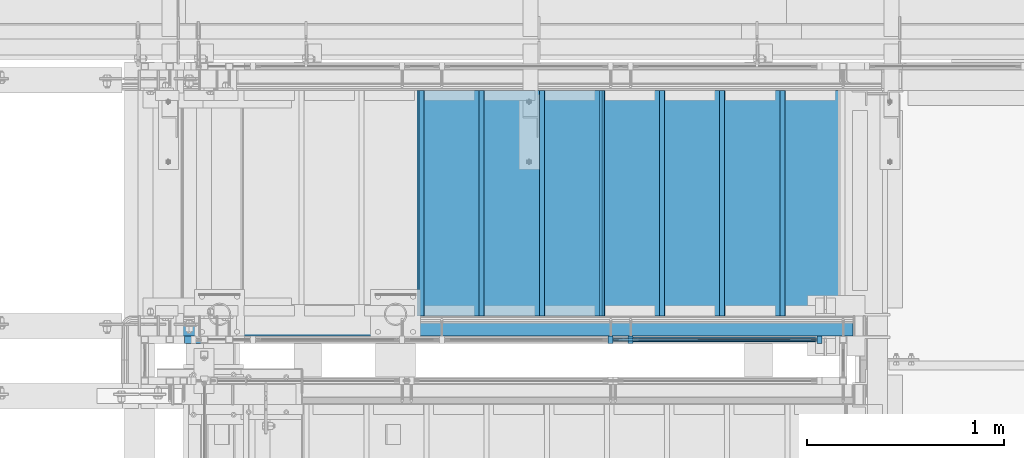
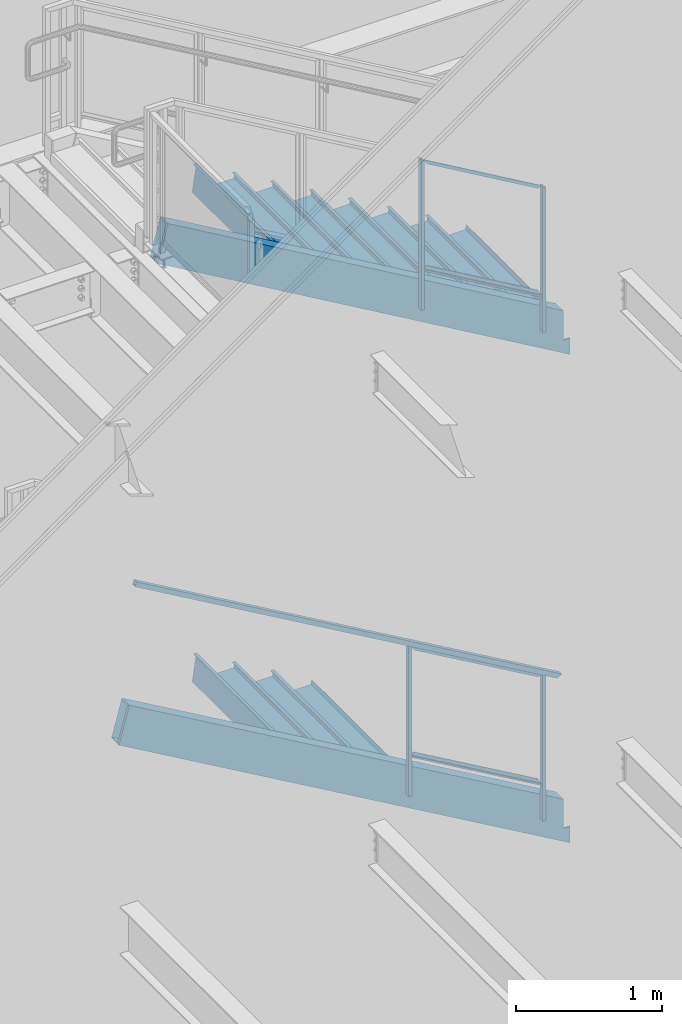
# One storey, part 795 of 1179: 14 beams, 9 members, 4 elements without a shape of their own.
"""IFC2X3 building model written with IfcOpenShell, lengths in millimetres."""

from ifc_helpers import new_model, si_unit, frame, origin_with_axes, place, context, subcontext, project, spatial, faceted_brep, material, type_object, element, aggregate, save


model = new_model("IFC2X3")

# Units and contexts
model_context = context("Model", 3, precision=1e-05, world=origin_with_axes())
body_context = subcontext(model_context, "Body", "Model", "MODEL_VIEW")
ifc_project = project(units=[si_unit("LENGTHUNIT", "METRE", prefix="MILLI"), si_unit("AREAUNIT", "SQUARE_METRE"), si_unit("VOLUMEUNIT", "CUBIC_METRE"), si_unit("MASSUNIT", "GRAM", prefix="KILO"), si_unit("TIMEUNIT", "SECOND"), si_unit("PLANEANGLEUNIT", "RADIAN"), si_unit("SOLIDANGLEUNIT", "STERADIAN"), si_unit("THERMODYNAMICTEMPERATUREUNIT", "DEGREE_CELSIUS"), si_unit("LUMINOUSINTENSITYUNIT", "LUMEN")], contexts=[model_context])

# Site, building, storey
site_placement = place(None, origin_with_axes())
site = spatial("IfcSite", under=ifc_project, at=site_placement, CompositionType="ELEMENT")
building_placement = place(site_placement, origin_with_axes())
building = spatial("IfcBuilding", under=site, at=building_placement, Name="Undefined", CompositionType="ELEMENT")
storey_placement = place(building_placement, origin_with_axes())
storey = spatial("IfcBuildingStorey", under=building, at=storey_placement, Name="Undefined", CompositionType="ELEMENT", Elevation=0.0)

# Assembly, member
assembly_1_placement = place(storey_placement, origin_with_axes())
assembly_1 = element("IfcElementAssembly", 1, at=assembly_1_placement, inside=storey, Name="GUARDRAIL", AssemblyPlace="NOTDEFINED", PredefinedType="RIGID_FRAME")
ifc_material_1 = material(Name="STEEL/A36")
member_type_1 = type_object("IfcMemberType", PredefinedType="NOTDEFINED")
member_1_placement = place(assembly_1_placement, frame((22723.4748880622, 39681.150000778, 2202.22061306289), z_axis=(0.0, -1.0, 0.0), x_axis=(0.0, 0.0, 1.0)))
member_1 = element("IfcMember", 2, at=member_1_placement, type_object=member_type_1, material=ifc_material_1, Name="POST", context=body_context, shape_type="Brep", body=[
    faceted_brep([(0.0, 12.7000000000007, -19.0500000000029), (0.0, 12.7000000000007, 19.0500000000029), (1219.49245899352, 12.7000000000007, 19.0500000000029), (1219.49245899352, 12.7000000000007, -19.0500000000029), (0.0, -12.7000000000007, 19.0500000000029), (1204.7860353781, -12.7000000000007, 19.0500000000029), (0.0, -12.7000000000007, -19.0500000000029), (1204.7860353781, -12.7000000000007, -19.0500000000029)], [[[0, 1, 2, 3]], [[1, 4, 5, 2]], [[4, 6, 7, 5]], [[6, 0, 3, 7]], [[5, 7, 3, 2]], [[6, 4, 1, 0]]]),
])

# Assembly, members
assembly_2_placement = place(storey_placement, origin_with_axes())
assembly_2 = element("IfcElementAssembly", 3, at=assembly_2_placement, inside=storey, Name="GUARDRAIL", AssemblyPlace="NOTDEFINED", PredefinedType="RIGID_FRAME")
member_2_placement = place(assembly_2_placement, frame((21766.7416677555, 39681.1500007796, 6797.24014827395), z_axis=(0.0, -1.0, 0.0), x_axis=(0.0, 0.0, 1.0)))
member_2 = element("IfcMember", 4, at=member_2_placement, type_object=member_type_1, material=ifc_material_1, Name="POST", context=body_context, shape_type="Brep", body=[
    faceted_brep([(0.0, 12.7000000000007, -19.0500000000029), (0.0, 12.7000000000007, 19.0500000000029), (1257.9937907086, 12.7000000000007, 19.0500000000029), (1257.9937907086, 12.7000000000007, -19.0500000000029), (0.0, -12.7000000000007, 19.0500000000029), (1243.17712405909, -12.7000000000007, 19.0500000000029), (0.0, -12.7000000000007, -19.0500000000029), (1243.17712405909, -12.7000000000007, -19.0500000000029)], [[[0, 1, 2, 3]], [[1, 4, 5, 2]], [[4, 6, 7, 5]], [[6, 0, 3, 7]], [[5, 7, 3, 2]], [[6, 4, 1, 0]]]),
])
member_3_placement = place(assembly_2_placement, frame((22723.4750016698, 39681.1500007796, 6275.74561220699), z_axis=(0.0, -1.0, 0.0), x_axis=(0.0, 0.0, 1.0)))
member_3 = element("IfcMember", 5, at=member_3_placement, type_object=member_type_1, material=ifc_material_1, Name="POST", context=body_context, shape_type="Brep", body=[
    faceted_brep([(1221.39388394322, 12.7000000000007, 19.0500000025713), (1206.57721729368, -12.7000000000007, 19.0500000000029), (1206.57721729368, -12.7000000000007, -19.0500000000029), (1221.39388394322, 12.7000000000007, -19.0500000000029), (0.0, -12.7000000000007, -19.0500000000029), (0.0, -12.7000000000007, 19.0500000000029), (0.0, 12.7000000000007, 19.0500000000029), (0.0, 12.7000000000007, -19.0500000000029)], [[[0, 1, 2, 3]], [[4, 5, 6, 7]], [[7, 6, 0, 3]], [[4, 7, 3, 2]], [[5, 4, 2, 1]], [[6, 5, 1, 0]]]),
])

# Member
member_4_placement = place(assembly_1_placement, frame((21666.1999246046, 39681.150000778, 2776.27547489678), z_axis=(0.0, -1.0, 0.0), x_axis=(0.0, 0.0, 1.0)))
member_4 = element("IfcMember", 6, at=member_4_placement, type_object=member_type_1, material=ifc_material_1, Name="POST", context=body_context, shape_type="Brep", body=[
    faceted_brep([(0.0, 12.7000000000007, -19.0500000000029), (0.0, 12.7000000000007, 19.0500000000029), (1257.59245944594, 12.7000000000007, 19.0500000000029), (1257.59245944594, 12.7000000000007, -19.0500000000029), (0.0, -12.7000000000007, 19.0500000000029), (1242.88603583053, -12.7000000000007, 19.0500000000029), (0.0, -12.7000000000007, -19.0500000000029), (1242.88603583053, -12.7000000000007, -19.0500000000029)], [[[0, 1, 2, 3]], [[1, 4, 5, 2]], [[4, 6, 7, 5]], [[6, 0, 3, 7]], [[5, 7, 3, 2]], [[6, 4, 1, 0]]]),
])

# Beam
ifc_material_2 = material(Name="STEEL/BUY-OUT")
beam_type_1 = type_object("IfcBeamType", PredefinedType="NOTDEFINED")
beam_1_placement = place(assembly_2_placement, frame((22257.9955253914, 39677.9751661883, 6880.08582790695), z_axis=(0.863778851027978, 0.0, -0.503871111016285), x_axis=(-0.503871111016286, 0.0, -0.863778851027978)))
beam_1 = element("IfcBeam", 7, at=beam_1_placement, type_object=beam_type_1, material=ifc_material_2, Name="U-EDGE", context=body_context, shape_type="Brep", body=[
    faceted_brep([(5.85307134315372e-07, 7.9375000095315, 493.146654191507), (25.4000002943358, 7.93750001315493, 537.368999999748), (25.4000002935682, 7.93749998683779, -537.369000000126), (5.89814590057358e-07, 7.93749998989369, -522.778334533057), (5.85307134315372e-07, 4.76250000952859, 493.146654191507), (5.89814590057358e-07, 4.76249998989806, -522.778334533057), (22.2250002943329, 4.76250001302105, 531.841205669258), (22.2250002935725, 4.76249998688581, -535.543713894371), (22.2250003046174, 1.58750000000146, 531.841205687164), (22.2250002832152, 1.58750000000146, -535.543713888419), (3.49245965480804e-10, 1.58750000000146, 493.146653173078), (-3.78349795937538e-10, 1.58750000000146, -522.778334194069), (3.49245965480804e-10, -1.58750000000146, 493.146653173078), (-3.78349795937538e-10, -1.58750000000146, -522.778334194069), (25.4000003047295, -1.58750000000146, 537.368999999901), (25.4000002831781, -1.58750000000146, -537.36899999997)], [[[0, 1, 2, 3]], [[4, 0, 3, 5]], [[6, 4, 5, 7]], [[8, 6, 7, 9]], [[10, 8, 9, 11]], [[12, 10, 11, 13]], [[14, 12, 13, 15]], [[11, 9, 7, 5, 3, 2, 15, 13]], [[1, 14, 15, 2]], [[0, 4, 6, 8, 10, 12, 14, 1]]]),
])

beam_2_placement = place(assembly_2_placement, frame((22232.3988480446, 39677.9751661883, 7745.06670437852), z_axis=(0.863778851027978, 0.0, -0.503871111016285), x_axis=(0.503871025088838, 0.0, 0.863778901152328)))
beam_2 = element("IfcBeam", 8, at=beam_2_placement, type_object=beam_type_1, material=ifc_material_2, Name="U-EDGE", context=body_context, shape_type="Brep", body=[
    faceted_brep([(8.44738679006696e-09, -4.76249999999709, -493.146660186705), (8.44738679006696e-09, -7.9375, -493.146660186705), (8.65475158207119e-09, -7.9375, 522.779993519576), (8.65475158207119e-09, -4.76249999999709, 522.779993519576), (22.2250000040658, -4.76249999999709, -531.84120750705), (22.2250000042877, -4.76249999999709, 535.54537418879), (22.2250000040658, -1.58750000000146, -531.84120750705), (22.2250000042877, -1.58750000000146, 535.54537418879), (-1.01863406598568e-10, -1.58750000000146, -493.146660171822), (1.09139364212751e-10, -1.58750000000146, 522.779993514665), (-1.01863406598568e-10, 1.58750000000146, -493.146660171822), (1.09139364212751e-10, 1.58750000000146, 522.779993514665), (25.4000000040614, 1.58750000000146, -537.368999999624), (25.400000004287, 1.58750000000146, 537.368999999613), (25.4000000040614, -7.9375, -537.368999999624), (25.400000004287, -7.9375, 537.368999999613)], [[[0, 1, 2, 3]], [[4, 0, 3, 5]], [[6, 4, 5, 7]], [[8, 6, 7, 9]], [[10, 8, 9, 11]], [[12, 10, 11, 13]], [[14, 12, 13, 15]], [[11, 9, 7, 5, 3, 2, 15, 13]], [[1, 14, 15, 2]], [[0, 4, 6, 8, 10, 12, 14, 1]]]),
])

beam_3_placement = place(assembly_1_placement, frame((22207.4122472657, 39677.9751661867, 2831.43122798005), z_axis=(0.86540914081268, 0.0, -0.501065882891521), x_axis=(-0.501065882891527, 0.0, -0.865409140812677)))
beam_3 = element("IfcBeam", 9, at=beam_3_placement, type_object=beam_type_1, material=ifc_material_2, Name="U-EDGE", context=body_context, shape_type="Brep", body=[
    faceted_brep([(-2.17914930544794e-09, 1.58750000000146, -579.8750616161), (-2.17914930544794e-09, -1.58750000000146, -579.8750616161), (2.06819095183164e-09, -1.58750000000146, 550.462303003866), (2.06819095183164e-09, 1.58750000000146, 550.462303003866), (22.2250000220702, 1.58750000000146, -592.688577145202), (22.225000051898, 1.58750000000146, 589.01191290709), (22.225000034794, 4.76249998386629, -592.688577152541), (22.2250000392505, 4.7625000160333, 589.011912885151), (7.50696926843375e-08, 4.76249998754065, -579.875061660634), (7.28450686438009e-08, 4.7625000118278, 550.462303126626), (7.50696926843375e-08, 7.93749998753628, -579.875061660634), (7.28450686438009e-08, 7.93750001182343, 550.462303126626), (25.4000000347896, 7.93749998381099, -594.518999999977), (25.4000000343149, 7.9375, 594.519), (25.4000000220258, -1.58750000000146, -594.518999999807), (25.4000000343149, -1.58750000000146, 594.519)], [[[0, 1, 2, 3]], [[4, 0, 3, 5]], [[6, 4, 5, 7]], [[8, 6, 7, 9]], [[10, 8, 9, 11]], [[12, 10, 11, 13]], [[14, 12, 13, 15]], [[11, 9, 7, 5, 3, 2, 15, 13]], [[1, 14, 15, 2]], [[0, 4, 6, 8, 10, 12, 14, 1]]]),
])

beam_4_placement = place(assembly_1_placement, frame((22181.9581376491, 39677.9751661867, 3697.10650203671), z_axis=(0.86540914081268, 0.0, -0.501065882891521), x_axis=(0.501065882891522, 0.0, 0.865409140812679)))
beam_4 = element("IfcBeam", 10, at=beam_4_placement, type_object=beam_type_1, material=ifc_material_2, Name="U-EDGE", context=body_context, shape_type="Brep", body=[
    faceted_brep([(-5.08043740410358e-09, -4.76250001176231, -550.462297073285), (-5.08043740410358e-09, -7.93750001176522, -550.462297073285), (2.06819095183164e-09, -7.93749998760177, 579.875144306196), (2.06819095183164e-09, -4.76249998760613, 579.875144306196), (22.2249999989635, -4.76250001590233, -589.011912123857), (22.2249999997566, -4.76249998399726, 592.68851804268), (22.2250000115582, -1.58750000000146, -589.011912145696), (22.2249999870892, -1.58750000000146, 592.68851803538), (-3.47426976077259e-10, -1.58750000000146, -550.462297081494), (3.69254848919809e-10, -1.58750000000146, 579.875144305217), (-3.47426976077259e-10, 1.58750000000146, -550.462297081494), (3.69254848919809e-10, 1.58750000000146, 579.875144305217), (25.4000001784334, 1.58750000000146, -594.51900000087), (25.3999999489688, 1.58750000000146, 594.519), (25.4000002532193, -7.93749990531796, -594.51900000187), (25.3999999489688, -7.9375, 594.519)], [[[0, 1, 2, 3]], [[4, 0, 3, 5]], [[6, 4, 5, 7]], [[8, 6, 7, 9]], [[10, 8, 9, 11]], [[12, 10, 11, 13]], [[14, 12, 13, 15]], [[11, 9, 7, 5, 3, 2, 15, 13]], [[1, 14, 15, 2]], [[0, 4, 6, 8, 10, 12, 14, 1]]]),
])

# Member
ifc_material_3 = material()
member_type_2 = type_object("IfcMemberType", Name="HSS1-1/2X1-1/2X1/8", PredefinedType="NOTDEFINED")
member_5_placement = place(assembly_1_placement, frame((19500.8500004143, 39681.150000777, 5302.25), z_axis=(0.501065882891522, 0.0, 0.865409140812679), x_axis=(0.86540914081268, 0.0, -0.501065882891521)))
member_5 = element("IfcMember", 11, at=member_5_placement, type_object=member_type_2, material=ifc_material_3, Name="GUARDRAIL", ObjectType="HSS1-1/2X1-1/2X1/8", context=body_context, shape_type="Brep", body=[
    faceted_brep([(4.26416977440931, 15.874999282998, -15.8749992829853), (4.26416977440931, -15.874999282998, -15.8749992829853), (3854.07797402598, -15.874999282998, -15.8749992812482), (3854.07797402598, 15.874999282998, -15.8749992812482), (-4.2641689637494, -15.874999282998, 15.8749992829908), (3872.38279282469, -15.874999282998, 15.8749992847406), (-4.2641689637494, 15.874999282998, 15.8749992829908), (3872.38279282469, 15.874999282998, 15.8749992847406), (5.11700367385129, 19.0499992350015, -19.0499992349851), (-5.11700286318955, 19.0499992350015, 19.0499992349887), (3874.21327475956, 19.0499992350015, 19.0499992367404), (3852.24749209111, 19.0499992350015, -19.0499992332479), (-5.11700286318955, -19.0499992350015, 19.0499992349887), (3874.21327475956, -19.0499992350015, 19.0499992367404), (5.11700367385129, -19.0499992350015, -19.0499992349851), (3852.24749209111, -19.0499992350015, -19.0499992332479)], [[[0, 1, 2, 3]], [[1, 4, 5, 2]], [[4, 6, 7, 5]], [[6, 0, 3, 7]], [[8, 9, 10, 11]], [[9, 12, 13, 10]], [[12, 14, 15, 13]], [[14, 8, 11, 15]], [[13, 15, 11, 10], [5, 7, 3, 2]], [[14, 12, 9, 8], [6, 4, 1, 0]]]),
])

member_type_3 = type_object("IfcMemberType", PredefinedType="NOTDEFINED")
member_6_placement = place(assembly_2_placement, frame((21766.7416677555, 39681.1500007796, 7128.05397063944), z_axis=(0.0, -1.0, 0.0), x_axis=(0.863778851027978, 0.0, -0.503871111016285)))
member_6 = element("IfcMember", 12, at=member_6_placement, type_object=member_type_3, material=ifc_material_1, Name="BOTTOM_RAIL", context=body_context, shape_type="Brep", body=[
    faceted_brep([(1096.61501763624, -6.34999999974752, 12.6999999999971), (1096.61501763624, -6.34999999974752, -12.6999999999971), (1089.20668431148, 6.35000000024229, -12.6999999999971), (1089.20668431148, 6.35000000024229, 12.6999999999971), (18.4070032121654, -6.34999999999127, -12.6999999999971), (18.4070032121654, -6.34999999999127, 12.6999999999971), (10.9986698874163, 6.34999999999854, 12.6999999999971), (10.9986698874163, 6.34999999999854, -12.6999999999971)], [[[0, 1, 2, 3]], [[4, 5, 6, 7]], [[6, 5, 0, 3]], [[7, 6, 3, 2]], [[4, 7, 2, 1]], [[5, 4, 1, 0]]]),
])

aggregate(assembly_2, [beam_1, beam_2, member_6, member_2, member_3])

member_7_placement = place(assembly_1_placement, frame((21666.1999246046, 39681.150000778, 3106.46611713066), z_axis=(0.0, -1.0, 0.0), x_axis=(0.86540914081268, 0.0, -0.501065882891521)))
member_7 = element("IfcMember", 13, at=member_7_placement, type_object=member_type_3, material=ifc_material_1, Name="BOTTOM_RAIL", context=body_context, shape_type="Brep", body=[
    faceted_brep([(10.998533752896, 6.34999999999854, -12.6999999999971), (10.998533752896, 6.34999999999854, 12.6999999999971), (1203.35358848741, 6.35000000053878, 12.6999999999971), (1203.35358848741, 6.35000000053878, -12.6999999999971), (18.3517455606161, -6.34999999998945, 12.6999999999971), (1210.70680029513, -6.34999999944921, 12.6999999999971), (18.3517455606161, -6.34999999998945, -12.6999999999971), (1210.70680029513, -6.34999999944921, -12.6999999999971)], [[[0, 1, 2, 3]], [[1, 4, 5, 2]], [[4, 6, 7, 5]], [[6, 0, 3, 7]], [[5, 7, 3, 2]], [[6, 4, 1, 0]]]),
])

aggregate(assembly_1, [beam_3, beam_4, member_1, member_7, member_4, member_5])

# Assembly, beams
assembly_3_placement = place(storey_placement, origin_with_axes())
assembly_3 = element("IfcElementAssembly", 14, at=assembly_3_placement, inside=storey, Name="STAIR", AssemblyPlace="NOTDEFINED", PredefinedType="RIGID_FRAME")
beam_type_2 = type_object("IfcBeamType", PredefinedType="NOTDEFINED")
beam_5_placement = place(assembly_3_placement, frame((20694.6500020447, 40373.3000000029, 7612.3600000093), z_axis=(0.0, 1.0, 0.0), x_axis=(1.0, 0.0, 0.0)))
beam_5 = element("IfcBeam", 15, at=beam_5_placement, type_object=beam_type_2, material=ifc_material_1, Name="TREAD", context=body_context, shape_type="Brep", body=[
    faceted_brep([(0.0, -1.28999999999996, -571.5), (0.0, -1.28999999999996, 571.5), (0.0, 1.28999999999996, 571.5), (0.0, 1.28999999999996, -571.5), (22.4252350064853, 1.28999999999996, 571.5), (22.4252350064853, 1.28999999999996, -571.5), (25.4000000000015, -1.28999999999996, -571.5), (25.4000000000015, -1.28999999999996, 571.5), (-10.2319078506589, 229.89, 571.5), (-10.2319078506589, 229.89, -571.5), (-7.25714285714275, 227.31, -571.5), (-7.25714285714275, 227.31, 571.5), (319.968697988821, 229.89, 571.5), (319.968697988821, 229.89, -571.5), (317.731075852447, 227.31, -571.5), (317.731075852447, 227.31, 571.5), (325.673299218732, 189.957791390602, 571.5), (325.673299218732, 189.957791390602, -571.5), (323.119229525088, 189.592924291511, 571.5), (323.119229525088, 189.592924291511, -571.5)], [[[0, 1, 2, 3]], [[3, 2, 4, 5]], [[1, 0, 6, 7]], [[5, 4, 8, 9]], [[7, 6, 10, 11]], [[9, 8, 12, 13]], [[11, 10, 14, 15]], [[13, 12, 16, 17]], [[12, 8, 4, 2, 1, 7, 11, 15, 18, 16]], [[15, 14, 19, 18]], [[14, 10, 6, 0, 3, 5, 9, 13, 17, 19]], [[18, 19, 17, 16]]]),
])
beam_6_placement = place(assembly_3_placement, frame((20999.4500017927, 40373.3000000029, 7434.5600000093), z_axis=(0.0, 1.0, 0.0), x_axis=(1.0, 0.0, 0.0)))
beam_6 = element("IfcBeam", 16, at=beam_6_placement, type_object=beam_type_2, material=ifc_material_1, Name="TREAD", context=body_context, shape_type="Brep", body=[
    faceted_brep([(0.0, -1.28999999999996, -571.5), (0.0, -1.28999999999996, 571.5), (0.0, 1.28999999999996, 571.5), (0.0, 1.28999999999996, -571.5), (22.4252350064853, 1.28999999999996, 571.5), (22.4252350064853, 1.28999999999996, -571.5), (25.4000000000015, -1.28999999999996, -571.5), (25.4000000000015, -1.28999999999996, 571.5), (-10.2319078506589, 229.89, 571.5), (-10.2319078506589, 229.89, -571.5), (-7.25714285714275, 227.31, -571.5), (-7.25714285714275, 227.31, 571.5), (319.968697988821, 229.89, 571.5), (319.968697988821, 229.89, -571.5), (317.731075852447, 227.31, -571.5), (317.731075852447, 227.31, 571.5), (325.673299218732, 189.957791390602, 571.5), (325.673299218732, 189.957791390602, -571.5), (323.119229525088, 189.592924291511, 571.5), (323.119229525088, 189.592924291511, -571.5)], [[[0, 1, 2, 3]], [[3, 2, 4, 5]], [[1, 0, 6, 7]], [[5, 4, 8, 9]], [[7, 6, 10, 11]], [[9, 8, 12, 13]], [[11, 10, 14, 15]], [[13, 12, 16, 17]], [[12, 8, 4, 2, 1, 7, 11, 15, 18, 16]], [[15, 14, 19, 18]], [[14, 10, 6, 0, 3, 5, 9, 13, 17, 19]], [[18, 19, 17, 16]]]),
])
beam_7_placement = place(assembly_3_placement, frame((21304.2500015406, 40373.3000000029, 7256.7600000093), z_axis=(0.0, 1.0, 0.0), x_axis=(1.0, 0.0, 0.0)))
beam_7 = element("IfcBeam", 17, at=beam_7_placement, type_object=beam_type_2, material=ifc_material_1, Name="TREAD", context=body_context, shape_type="Brep", body=[
    faceted_brep([(0.0, -1.28999999999996, -571.5), (0.0, -1.28999999999996, 571.5), (0.0, 1.28999999999996, 571.5), (0.0, 1.28999999999996, -571.5), (22.4252350064853, 1.28999999999996, 571.5), (22.4252350064853, 1.28999999999996, -571.5), (25.4000000000015, -1.28999999999996, -571.5), (25.4000000000015, -1.28999999999996, 571.5), (-10.2319078506589, 229.89, 571.5), (-10.2319078506589, 229.89, -571.5), (-7.25714285714275, 227.31, -571.5), (-7.25714285714275, 227.31, 571.5), (319.968697988821, 229.89, 571.5), (319.968697988821, 229.89, -571.5), (317.731075852447, 227.31, -571.5), (317.731075852447, 227.31, 571.5), (325.673299218732, 189.957791390602, 571.5), (325.673299218732, 189.957791390602, -571.5), (323.119229525088, 189.592924291511, 571.5), (323.119229525088, 189.592924291511, -571.5)], [[[0, 1, 2, 3]], [[3, 2, 4, 5]], [[1, 0, 6, 7]], [[5, 4, 8, 9]], [[7, 6, 10, 11]], [[9, 8, 12, 13]], [[11, 10, 14, 15]], [[13, 12, 16, 17]], [[12, 8, 4, 2, 1, 7, 11, 15, 18, 16]], [[15, 14, 19, 18]], [[14, 10, 6, 0, 3, 5, 9, 13, 17, 19]], [[18, 19, 17, 16]]]),
])
beam_8_placement = place(assembly_3_placement, frame((21609.0500012886, 40373.3000000029, 7078.9600000093), z_axis=(0.0, 1.0, 0.0), x_axis=(1.0, 0.0, 0.0)))
beam_8 = element("IfcBeam", 18, at=beam_8_placement, type_object=beam_type_2, material=ifc_material_1, Name="TREAD", context=body_context, shape_type="Brep", body=[
    faceted_brep([(0.0, -1.28999999999996, -571.5), (0.0, -1.28999999999996, 571.5), (0.0, 1.28999999999996, 571.5), (0.0, 1.28999999999996, -571.5), (22.4252350064853, 1.28999999999996, 571.5), (22.4252350064853, 1.28999999999996, -571.5), (25.4000000000015, -1.28999999999996, -571.5), (25.4000000000015, -1.28999999999996, 571.5), (-10.2319078506589, 229.89, 571.5), (-10.2319078506589, 229.89, -571.5), (-7.25714285714275, 227.31, -571.5), (-7.25714285714275, 227.31, 571.5), (319.968697988821, 229.89, 571.5), (319.968697988821, 229.89, -571.5), (317.731075852447, 227.31, -571.5), (317.731075852447, 227.31, 571.5), (325.673299218732, 189.957791390602, 571.5), (325.673299218732, 189.957791390602, -571.5), (323.119229525088, 189.592924291511, 571.5), (323.119229525088, 189.592924291511, -571.5)], [[[0, 1, 2, 3]], [[3, 2, 4, 5]], [[1, 0, 6, 7]], [[5, 4, 8, 9]], [[7, 6, 10, 11]], [[9, 8, 12, 13]], [[11, 10, 14, 15]], [[13, 12, 16, 17]], [[12, 8, 4, 2, 1, 7, 11, 15, 18, 16]], [[15, 14, 19, 18]], [[14, 10, 6, 0, 3, 5, 9, 13, 17, 19]], [[18, 19, 17, 16]]]),
])
beam_9_placement = place(assembly_3_placement, frame((21913.8500010365, 40373.3000000029, 6901.1600000093), z_axis=(0.0, 1.0, 0.0), x_axis=(1.0, 0.0, 0.0)))
beam_9 = element("IfcBeam", 19, at=beam_9_placement, type_object=beam_type_2, material=ifc_material_1, Name="TREAD", context=body_context, shape_type="Brep", body=[
    faceted_brep([(0.0, -1.28999999999996, -571.5), (0.0, -1.28999999999996, 571.5), (0.0, 1.28999999999996, 571.5), (0.0, 1.28999999999996, -571.5), (22.4252350064853, 1.28999999999996, 571.5), (22.4252350064853, 1.28999999999996, -571.5), (25.4000000000015, -1.28999999999996, -571.5), (25.4000000000015, -1.28999999999996, 571.5), (-10.2319078506589, 229.89, 571.5), (-10.2319078506589, 229.89, -571.5), (-7.25714285714275, 227.31, -571.5), (-7.25714285714275, 227.31, 571.5), (319.968697988821, 229.89, 571.5), (319.968697988821, 229.89, -571.5), (317.731075852447, 227.31, -571.5), (317.731075852447, 227.31, 571.5), (325.673299218732, 189.957791390602, 571.5), (325.673299218732, 189.957791390602, -571.5), (323.119229525088, 189.592924291511, 571.5), (323.119229525088, 189.592924291511, -571.5)], [[[0, 1, 2, 3]], [[3, 2, 4, 5]], [[1, 0, 6, 7]], [[5, 4, 8, 9]], [[7, 6, 10, 11]], [[9, 8, 12, 13]], [[11, 10, 14, 15]], [[13, 12, 16, 17]], [[12, 8, 4, 2, 1, 7, 11, 15, 18, 16]], [[15, 14, 19, 18]], [[14, 10, 6, 0, 3, 5, 9, 13, 17, 19]], [[18, 19, 17, 16]]]),
])
beam_10_placement = place(assembly_3_placement, frame((22218.6500007845, 40373.3000000029, 6723.3600000093), z_axis=(0.0, 1.0, 0.0), x_axis=(1.0, 0.0, 0.0)))
beam_10 = element("IfcBeam", 20, at=beam_10_placement, type_object=beam_type_2, material=ifc_material_1, Name="TREAD", context=body_context, shape_type="Brep", body=[
    faceted_brep([(0.0, -1.28999999999996, -571.5), (0.0, -1.28999999999996, 571.5), (0.0, 1.28999999999996, 571.5), (0.0, 1.28999999999996, -571.5), (22.4252350064853, 1.28999999999996, 571.5), (22.4252350064853, 1.28999999999996, -571.5), (25.4000000000015, -1.28999999999996, -571.5), (25.4000000000015, -1.28999999999996, 571.5), (-10.2319078506589, 229.89, 571.5), (-10.2319078506589, 229.89, -571.5), (-7.25714285714275, 227.31, -571.5), (-7.25714285714275, 227.31, 571.5), (319.968697988821, 229.89, 571.5), (319.968697988821, 229.89, -571.5), (317.731075852447, 227.31, -571.5), (317.731075852447, 227.31, 571.5), (325.673299218732, 189.957791390602, 571.5), (325.673299218732, 189.957791390602, -571.5), (323.119229525088, 189.592924291511, 571.5), (323.119229525088, 189.592924291511, -571.5)], [[[0, 1, 2, 3]], [[3, 2, 4, 5]], [[1, 0, 6, 7]], [[5, 4, 8, 9]], [[7, 6, 10, 11]], [[9, 8, 12, 13]], [[11, 10, 14, 15]], [[13, 12, 16, 17]], [[12, 8, 4, 2, 1, 7, 11, 15, 18, 16]], [[15, 14, 19, 18]], [[14, 10, 6, 0, 3, 5, 9, 13, 17, 19]], [[18, 19, 17, 16]]]),
])
beam_11_placement = place(assembly_3_placement, frame((22523.4500005324, 40373.3000000029, 6545.5600000093), z_axis=(0.0, 1.0, 0.0), x_axis=(1.0, 0.0, 0.0)))
beam_11 = element("IfcBeam", 21, at=beam_11_placement, type_object=beam_type_2, material=ifc_material_1, Name="TREAD", context=body_context, shape_type="Brep", body=[
    faceted_brep([(0.0, -1.28999999999996, -571.5), (0.0, -1.28999999999996, 571.5), (0.0, 1.28999999999996, 571.5), (0.0, 1.28999999999996, -571.5), (22.4252350064853, 1.28999999999996, 571.5), (22.4252350064853, 1.28999999999996, -571.5), (25.4000000000015, -1.28999999999996, -571.5), (25.4000000000015, -1.28999999999996, 571.5), (-10.2319078506589, 229.89, 571.5), (-10.2319078506589, 229.89, -571.5), (-7.25714285714275, 227.31, -571.5), (-7.25714285714275, 227.31, 571.5), (319.968697988821, 229.89, 571.5), (319.968697988821, 229.89, -571.5), (317.731075852447, 227.31, -571.5), (317.731075852447, 227.31, 571.5), (325.673299218732, 189.957791390602, 571.5), (325.673299218732, 189.957791390602, -571.5), (323.119229525088, 189.592924291511, 571.5), (323.119229525088, 189.592924291511, -571.5)], [[[0, 1, 2, 3]], [[3, 2, 4, 5]], [[1, 0, 6, 7]], [[5, 4, 8, 9]], [[7, 6, 10, 11]], [[9, 8, 12, 13]], [[11, 10, 14, 15]], [[13, 12, 16, 17]], [[12, 8, 4, 2, 1, 7, 11, 15, 18, 16]], [[15, 14, 19, 18]], [[14, 10, 6, 0, 3, 5, 9, 13, 17, 19]], [[18, 19, 17, 16]]]),
])

assembly_4_placement = place(storey_placement, origin_with_axes())
assembly_4 = element("IfcElementAssembly", 22, at=assembly_4_placement, inside=storey, Name="STAIR", AssemblyPlace="NOTDEFINED", PredefinedType="RIGID_FRAME")
beam_12_placement = place(assembly_4_placement, frame((20694.650000384, 40373.3000001154, 3528.25166626965), z_axis=(0.0, 1.0, 0.0), x_axis=(1.0, 0.0, 0.0)))
beam_12 = element("IfcBeam", 23, at=beam_12_placement, type_object=beam_type_2, material=ifc_material_1, Name="TREAD", context=body_context, shape_type="Brep", body=[
    faceted_brep([(0.0, -1.28999999999996, -571.5), (0.0, -1.28999999999996, 571.5), (0.0, 1.28999999999996, 571.5), (0.0, 1.28999999999996, -571.5), (22.4220799334253, 1.28999999999996, 571.5), (22.4220799334253, 1.28999999999996, -571.5), (25.4000000000015, -1.28999999999996, -571.5), (25.4000000000015, -1.28999999999996, 571.5), (-10.2894642965184, 228.56708328371, 571.5), (-10.2894642965184, 228.56708328371, -571.5), (-7.31154422994223, 225.98708328371, -571.5), (-7.31154422994223, 225.98708328371, 571.5), (319.911141878769, 228.56708328371, 571.5), (319.911141878769, 228.56708328371, -571.5), (317.675890478069, 225.98708328371, -571.5), (317.675890478069, 225.98708328371, 571.5), (325.657303794516, 188.643229151176, 571.5), (325.657303794516, 188.643229151176, -571.5), (323.103618368372, 188.27568222317, 571.5), (323.103618368372, 188.27568222317, -571.5)], [[[0, 1, 2, 3]], [[3, 2, 4, 5]], [[1, 0, 6, 7]], [[5, 4, 8, 9]], [[7, 6, 10, 11]], [[9, 8, 12, 13]], [[11, 10, 14, 15]], [[13, 12, 16, 17]], [[12, 8, 4, 2, 1, 7, 11, 15, 18, 16]], [[15, 14, 19, 18]], [[14, 10, 6, 0, 3, 5, 9, 13, 17, 19]], [[18, 19, 17, 16]]]),
])
beam_13_placement = place(assembly_4_placement, frame((20999.4500003766, 40373.3000001154, 3351.77458298594), z_axis=(0.0, 1.0, 0.0), x_axis=(1.0, 0.0, 0.0)))
beam_13 = element("IfcBeam", 24, at=beam_13_placement, type_object=beam_type_2, material=ifc_material_1, Name="TREAD", context=body_context, shape_type="Brep", body=[
    faceted_brep([(0.0, -1.28999999999996, -571.5), (0.0, -1.28999999999996, 571.5), (0.0, 1.28999999999996, 571.5), (0.0, 1.28999999999996, -571.5), (22.4220799334253, 1.28999999999996, 571.5), (22.4220799334253, 1.28999999999996, -571.5), (25.4000000000015, -1.28999999999996, -571.5), (25.4000000000015, -1.28999999999996, 571.5), (-10.2894642965184, 228.56708328371, 571.5), (-10.2894642965184, 228.56708328371, -571.5), (-7.31154422994223, 225.98708328371, -571.5), (-7.31154422994223, 225.98708328371, 571.5), (319.911141878769, 228.56708328371, 571.5), (319.911141878769, 228.56708328371, -571.5), (317.675890478069, 225.98708328371, -571.5), (317.675890478069, 225.98708328371, 571.5), (325.657303794516, 188.643229151176, 571.5), (325.657303794516, 188.643229151176, -571.5), (323.103618368372, 188.27568222317, 571.5), (323.103618368372, 188.27568222317, -571.5)], [[[0, 1, 2, 3]], [[3, 2, 4, 5]], [[1, 0, 6, 7]], [[5, 4, 8, 9]], [[7, 6, 10, 11]], [[9, 8, 12, 13]], [[11, 10, 14, 15]], [[13, 12, 16, 17]], [[12, 8, 4, 2, 1, 7, 11, 15, 18, 16]], [[15, 14, 19, 18]], [[14, 10, 6, 0, 3, 5, 9, 13, 17, 19]], [[18, 19, 17, 16]]]),
])
beam_14_placement = place(assembly_4_placement, frame((21304.2500003691, 40373.3000001154, 3175.29749970223), z_axis=(0.0, 1.0, 0.0), x_axis=(1.0, 0.0, 0.0)))
beam_14 = element("IfcBeam", 25, at=beam_14_placement, type_object=beam_type_2, material=ifc_material_1, Name="TREAD", context=body_context, shape_type="Brep", body=[
    faceted_brep([(0.0, -1.28999999999996, -571.5), (0.0, -1.28999999999996, 571.5), (0.0, 1.28999999999996, 571.5), (0.0, 1.28999999999996, -571.5), (22.4220799334253, 1.28999999999996, 571.5), (22.4220799334253, 1.28999999999996, -571.5), (25.4000000000015, -1.28999999999996, -571.5), (25.4000000000015, -1.28999999999996, 571.5), (-10.2894642965184, 228.56708328371, 571.5), (-10.2894642965184, 228.56708328371, -571.5), (-7.31154422994223, 225.98708328371, -571.5), (-7.31154422994223, 225.98708328371, 571.5), (319.911141878769, 228.56708328371, 571.5), (319.911141878769, 228.56708328371, -571.5), (317.675890478069, 225.98708328371, -571.5), (317.675890478069, 225.98708328371, 571.5), (325.657303794516, 188.643229151176, 571.5), (325.657303794516, 188.643229151176, -571.5), (323.103618368372, 188.27568222317, 571.5), (323.103618368372, 188.27568222317, -571.5)], [[[0, 1, 2, 3]], [[3, 2, 4, 5]], [[1, 0, 6, 7]], [[5, 4, 8, 9]], [[7, 6, 10, 11]], [[9, 8, 12, 13]], [[11, 10, 14, 15]], [[13, 12, 16, 17]], [[12, 8, 4, 2, 1, 7, 11, 15, 18, 16]], [[15, 14, 19, 18]], [[14, 10, 6, 0, 3, 5, 9, 13, 17, 19]], [[18, 19, 17, 16]]]),
])

# Member
member_type_4 = type_object("IfcMemberType", Name="HSS12X4X3/8", PredefinedType="NOTDEFINED")
member_8_placement = place(assembly_3_placement, frame((19692.1840695408, 39751.000000012, 8066.21009552207), z_axis=(0.503871025088838, 0.0, 0.863778901152328), x_axis=(0.863778851027978, 0.0, -0.503871111016285)))
member_8 = element("IfcMember", 26, at=member_8_placement, type_object=member_type_4, material=ifc_material_3, Name="STAIR", ObjectType="HSS12X4X3/8", context=body_context, shape_type="Brep", body=[
    faceted_brep([(92.2693648904242, 50.8000000000029, -152.399999999852), (79.827342666882, 41.2750000000015, -142.875), (2.57507555327538, 41.2750000000015, 142.875), (9.86694677204468, 50.8000000000029, 152.39999999994), (79.827342666882, -41.2750000000015, -142.875), (92.2693648904242, -50.8000000000029, -152.399999996655), (9.86694677204105, -50.8000000000029, 152.400000000649), (2.57507555327538, -41.2750000000015, 142.875), (3788.14533025769, 41.2750000000015, -33.722079731866), (3788.14533025769, 50.8000000000029, -33.722079731866), (3742.89411344609, 50.8000000000029, -60.1186228916522), (3742.89411344609, 41.2750000000015, -60.1186228916522), (3857.37411742906, 50.8000000000029, -152.399999996509), (3857.37411742906, -50.8000000000029, -152.400000008463), (3618.92491637227, 50.8000000000029, 152.400000003145), (3851.81786739456, -41.2750000000015, -142.874999996518), (3851.81786739456, 41.2750000000015, -142.874999996518), (3624.48116638743, 41.2750000000015, 142.875000003154), (3624.48116638743, -41.2750000000015, 142.875000003154), (3618.92491637227, -50.8000000000029, 152.400000003145), (3742.89411344609, -50.8000000000029, -60.1186228916522), (3742.89411344609, -41.2750000000015, -60.1186228916522), (3788.14533025769, -50.8000000000029, -33.722079731866), (3788.14533025769, -41.2750000000015, -33.722079731866)], [[[0, 1, 2, 3]], [[4, 5, 6, 7]], [[5, 4, 1, 0]], [[8, 9, 10, 11]], [[12, 13, 5, 0]], [[14, 10, 9, 12, 0, 3]], [[15, 16, 1, 4]], [[11, 17, 2, 1, 16, 8]], [[17, 18, 7, 2]], [[7, 6, 3, 2]], [[19, 14, 3, 6]], [[20, 21, 18, 17, 11, 10, 14, 19]], [[22, 23, 21, 20]], [[13, 12, 9, 8, 16, 15, 23, 22]], [[4, 7, 18, 21, 23, 15]], [[13, 22, 20, 19, 6, 5]]]),
])

aggregate(assembly_3, [beam_5, beam_6, beam_7, beam_8, beam_9, beam_10, beam_11, member_8])

member_9_placement = place(assembly_4_placement, frame((19387.440965833, 39751.0000000359, 4154.3616463178), z_axis=(0.501065882891522, 0.0, 0.865409140812679), x_axis=(0.86540914081268, 0.0, -0.501065882891521)))
member_9 = element("IfcMember", 27, at=member_9_placement, type_object=member_type_4, material=ifc_material_3, Name="STAIR", ObjectType="HSS12X4X3/8", context=body_context, shape_type="Brep", body=[
    faceted_brep([(79.3135518111412, -41.2750000000015, -142.875), (91.7346902094068, -50.8000000000006, -152.400000000034), (9.86305989554967, -50.8000000000029, 152.399999999416), (2.55849975384263, -41.2750000000015, 142.875), (91.7346902094068, 50.7999999999997, -152.400000000034), (79.3135518111412, 41.2750000000015, -142.875), (2.55849975384263, 41.2750000000015, 142.875), (9.86305989554967, 50.8000000000029, 152.399999999909), (4196.23638222987, -41.2750000000015, -142.874999998012), (4196.23638222987, 41.2750000000015, -142.874999998012), (4201.75129108567, -50.8000000000029, -152.399999998002), (4201.75129108567, 50.8000000000029, -152.399999998002), (4132.753898134, 50.8000000000029, -33.2320889682906), (4132.753898134, 41.2750000000015, -33.2320889682906), (4132.753898134, -41.2750000000015, -33.2320889682906), (4132.75389826523, -50.8000000000029, -33.2320888923095), (3964.73925682746, 50.8000000000029, 152.400000001697), (4087.417277369, 50.8000000000029, -59.4816776154912), (4087.417277369, 41.2750000000015, -59.4816776154912), (3970.25416570867, 41.2750000000015, 142.875000001704), (3970.25416570867, -41.2750000000015, 142.875000001704), (3964.73925682746, -50.8000000000029, 152.400000001697), (4087.417277369, -50.8000000000029, -59.4816776154912), (4087.417277369, -41.2750000000015, -59.4816776154912)], [[[0, 1, 2, 3]], [[4, 5, 6, 7]], [[5, 4, 1, 0]], [[8, 9, 5, 0]], [[10, 11, 12, 13, 9, 8, 14, 15]], [[11, 10, 1, 4]], [[16, 17, 12, 11, 4, 7]], [[13, 12, 17, 18]], [[19, 6, 5, 9, 13, 18]], [[19, 20, 3, 6]], [[7, 6, 3, 2]], [[21, 16, 7, 2]], [[22, 23, 20, 19, 18, 17, 16, 21]], [[15, 14, 23, 22]], [[8, 0, 3, 20, 23, 14]], [[10, 15, 22, 21, 2, 1]]]),
])

aggregate(assembly_4, [beam_12, beam_13, beam_14, member_9])

save(model, "model.ifc")
